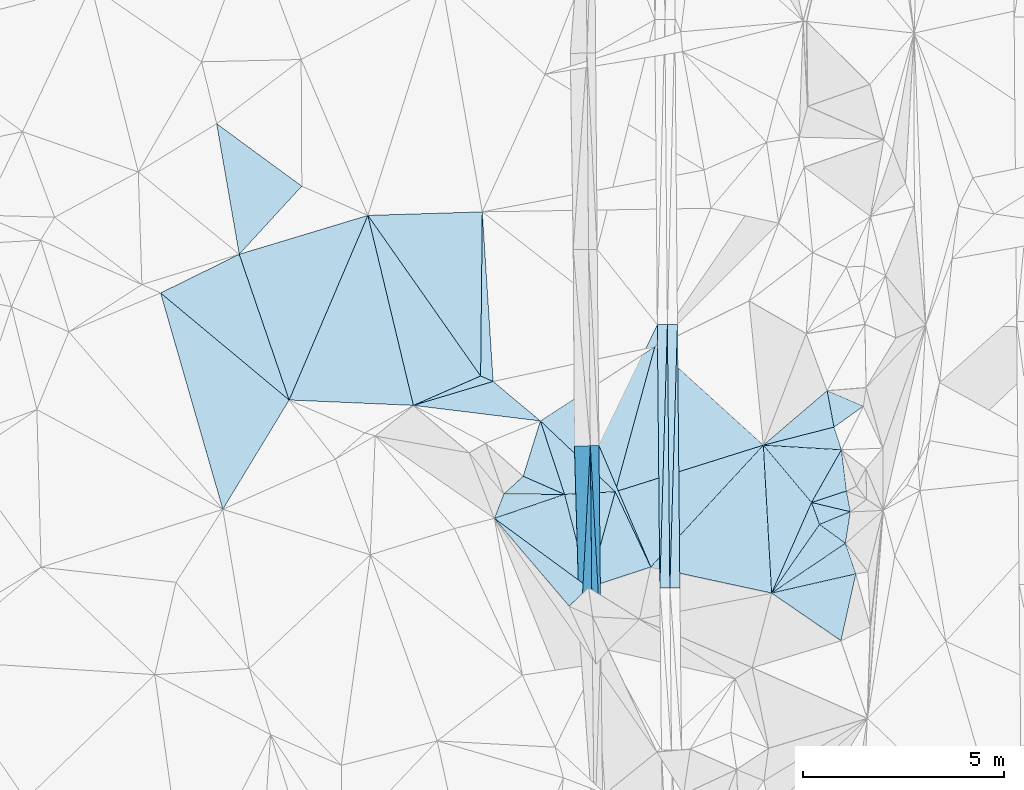
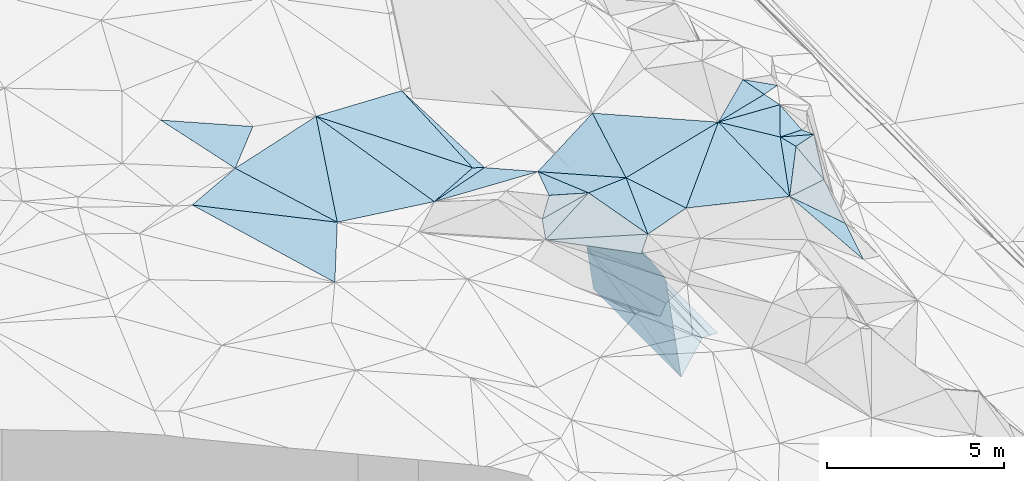
# One storey, part 18 of 275: 45 plates.
"""IFC2X3 building model written with IfcOpenShell, lengths in millimetres."""

from ifc_helpers import new_model, si_unit, frame, origin_with_axes, place, context, subcontext, project, spatial, polyline, outline, extrude, material, type_object, element, save


model = new_model("IFC2X3")

# Units and contexts
model_context = context("Model", 3, precision=1e-05, world=origin_with_axes())
body_context = subcontext(model_context, "Body", "Model", "MODEL_VIEW")
ifc_project = project(units=[si_unit("LENGTHUNIT", "METRE", prefix="MILLI"), si_unit("AREAUNIT", "SQUARE_METRE"), si_unit("VOLUMEUNIT", "CUBIC_METRE"), si_unit("MASSUNIT", "GRAM", prefix="KILO"), si_unit("TIMEUNIT", "SECOND"), si_unit("PLANEANGLEUNIT", "RADIAN"), si_unit("SOLIDANGLEUNIT", "STERADIAN"), si_unit("THERMODYNAMICTEMPERATUREUNIT", "DEGREE_CELSIUS"), si_unit("LUMINOUSINTENSITYUNIT", "LUMEN")], contexts=[model_context])

# Site, building, storey
site_placement = place(None, origin_with_axes())
site = spatial("IfcSite", under=ifc_project, at=site_placement, CompositionType="ELEMENT")
building_placement = place(site_placement, origin_with_axes())
building = spatial("IfcBuilding", under=site, at=building_placement, Name="Undefined", CompositionType="ELEMENT")
storey_placement = place(building_placement, origin_with_axes())
storey = spatial("IfcBuildingStorey", under=building, at=storey_placement, Name="Undefined", CompositionType="ELEMENT", Elevation=0.0)

# Plates
ifc_material = material()
plate_type_1 = type_object("IfcPlateType", PredefinedType="NOTDEFINED")
plate_1_placement = place(storey_placement, frame((-103609.10241154, 29331.890004464, 41830.4527314809), z_axis=(0.0497189597427629, 0.021119356383845, -0.998539933016216), x_axis=(0.00942336010166132, -0.999741827176861, -0.0206755719984943)))
element("IfcPlate", 1, at=plate_1_placement, inside=storey, type_object=plate_type_1, material=ifc_material, Name="00_PR", context=body_context, shape_type="SweptSolid", body=[
    extrude(outline(polyline([(0.0, 0.0), (6559.47998046875, 5.80621417611837e-09), (6559.8740234375, 250.312072753906), (0.0, 0.0)])), frame((-8.85201319254618e-08, 2.18876761149539e-07, -0.5000001331573), z_axis=(0.0, 0.0, 1.0), x_axis=(1.0, 0.0, 0.0)), (0.0, 0.0, 1.0), 1.0),
])
plate_2_placement = place(storey_placement, frame((-103859.092883656, 29329.669323517, 41817.9527319857), z_axis=(0.0497412450180932, 0.0211186916750077, -0.998538837204636), x_axis=(0.998712939479923, 0.00887162411305846, 0.0499375490084139)))
element("IfcPlate", 2, at=plate_2_placement, inside=storey, type_object=plate_type_1, material=ifc_material, Name="00_PR", context=body_context, shape_type="SweptSolid", body=[
    extrude(outline(polyline([(0.0, 0.0), (250.312698364258, -9.60426405072212e-10), (-3.21760201454163, 6559.75048828125), (0.0, 0.0)])), frame((-8.85201319254618e-08, 2.18876761149539e-07, -0.5000001331573), z_axis=(0.0, 0.0, 1.0), x_axis=(1.0, 0.0, 0.0)), (0.0, 0.0, 1.0), 1.0),
])
plate_3_placement = place(storey_placement, frame((-103547.325030308, 22774.1030868264, 41694.8312079371), z_axis=(-0.0201969752036263, 0.0204828383936473, -0.999586182139371), x_axis=(0.0286680488941595, 0.99939088915696, 0.0198995890073842)))
element("IfcPlate", 3, at=plate_3_placement, inside=storey, type_object=plate_type_1, material=ifc_material, Name="00_PR", context=body_context, shape_type="SweptSolid", body=[
    extrude(outline(polyline([(0.0, 0.0), (6564.0048828125, -3.34694050252438e-10), (9.55822658538818, 249.866928100586), (0.0, 0.0)])), frame((-8.85201319254618e-08, 2.18876761149539e-07, -0.5000001331573), z_axis=(0.0, 0.0, 1.0), x_axis=(1.0, 0.0, 0.0)), (0.0, 0.0, 1.0), 1.0),
])
plate_4_placement = place(storey_placement, frame((-103359.14779484, 29334.109961642, 41825.4522074339), z_axis=(-0.0201744797587791, 0.0204822013867093, -0.999586649467077), x_axis=(-0.0286680488809871, -0.999390889177604, -0.0198995879896055)))
element("IfcPlate", 4, at=plate_4_placement, inside=storey, type_object=plate_type_1, material=ifc_material, Name="00_PR", context=body_context, shape_type="SweptSolid", body=[
    extrude(outline(polyline([(0.0, 0.0), (6564.0048828125, -3.34694050252438e-10), (9.2861385345459, 249.876922607422), (0.0, 0.0)])), frame((-8.85201319254618e-08, 2.18876761149539e-07, -0.5000001331573), z_axis=(0.0, 0.0, 1.0), x_axis=(1.0, 0.0, 0.0)), (0.0, 0.0, 1.0), 1.0),
])
plate_type_2 = type_object("IfcPlateType", PredefinedType="NOTDEFINED")
plate_5_placement = place(storey_placement, frame((-99055.7095821679, 24674.3928783165, 45909.5237554857), z_axis=(-0.168807420396728, -0.253568631692106, -0.952474148646983), x_axis=(-0.966984833365667, 0.229769833923114, 0.110209597856621)))
element("IfcPlate", 5, at=plate_5_placement, inside=storey, type_object=plate_type_2, material=ifc_material, Name="00", context=body_context, shape_type="SweptSolid", body=[
    extrude(outline(polyline([(0.0, 0.0), (998.098205566406, -2.29920260608196e-09), (198.37727355957, 499.546264648438), (0.0, 0.0)])), frame((-8.85201319254618e-08, 2.18876761149539e-07, -0.5000001331573), z_axis=(0.0, 0.0, 1.0), x_axis=(1.0, 0.0, 0.0)), (0.0, 0.0, 1.0), 1.0),
])
plate_type_3 = type_object("IfcPlateType", PredefinedType="NOTDEFINED")
plate_6_placement = place(storey_placement, frame((-105264.390079401, 21434.0374164795, 41655.2352918188), z_axis=(-0.989926541019541, -0.00675050849142688, -0.141420910830731), x_axis=(-0.141414167012592, -0.00144075398867018, 0.989949472243952)))
element("IfcPlate", 6, at=plate_6_placement, inside=storey, type_object=plate_type_3, material=ifc_material, Name="00_PR", context=body_context, shape_type="SweptSolid", body=[
    extrude(outline(polyline([(0.0, 0.0), (1515.22888183594, -4.05998434871435e-09), (1615.31982421875, 4885.205078125), (0.0, 0.0)])), frame((-8.85201319254618e-08, 2.18876761149539e-07, -0.5000001331573), z_axis=(0.0, 0.0, 1.0), x_axis=(1.0, 0.0, 0.0)), (0.0, 0.0, 1.0), 1.0),
])
plate_7_placement = place(storey_placement, frame((-105526.460321508, 26316.7988611923, 43256.624291726), z_axis=(-0.989926541019541, -0.00675050849142688, -0.141420910830731), x_axis=(0.141415544961901, 0.0013266330082938, -0.989949434914728)))
element("IfcPlate", 7, at=plate_7_placement, inside=storey, type_object=plate_type_3, material=ifc_material, Name="00_PR", context=body_context, shape_type="SweptSolid", body=[
    extrude(outline(polyline([(0.0, 0.0), (1515.22888183594, -4.05998434871435e-09), (1615.87731933594, 4885.0205078125), (0.0, 0.0)])), frame((-8.85201319254618e-08, 2.18876761149539e-07, -0.5000001331573), z_axis=(0.0, 0.0, 1.0), x_axis=(1.0, 0.0, 0.0)), (0.0, 0.0, 1.0), 1.0),
])
plate_type_4 = type_object("IfcPlateType", PredefinedType="NOTDEFINED")
plate_8_placement = place(storey_placement, frame((-105526.460321508, 26316.7988611923, 43256.624291726), z_axis=(-0.989926541019541, -0.00675050849142688, -0.141420910830731), x_axis=(-0.0485562239280286, -0.922096443268798, 0.383901605139759)))
element("IfcPlate", 8, at=plate_8_placement, inside=storey, type_object=plate_type_4, material=ifc_material, Name="00_PR", context=body_context, shape_type="SweptSolid", body=[
    extrude(outline(polyline([(0.0, 0.0), (5301.0224609375, 2.91765900328755e-09), (1088.08190917969, 2583.6025390625), (0.0, 0.0)])), frame((-8.85201319254618e-08, 2.18876761149539e-07, -0.5000001331573), z_axis=(0.0, 0.0, 1.0), x_axis=(1.0, 0.0, 0.0)), (0.0, 0.0, 1.0), 1.0),
])
plate_type_5 = type_object("IfcPlateType", PredefinedType="NOTDEFINED")
plate_9_placement = place(storey_placement, frame((-105526.460321508, 26316.7988611923, 43256.624291726), z_axis=(-0.989926541019541, -0.00675050849142688, -0.141420910830731), x_axis=(0.00978165408462092, -0.999736844929714, -0.020749942972222)))
element("IfcPlate", 9, at=plate_9_placement, inside=storey, type_object=plate_type_5, material=ifc_material, Name="00_PR", context=body_context, shape_type="SweptSolid", body=[
    extrude(outline(polyline([(0.0, 0.0), (4886.23046875, 2.02999217435718e-09), (4842.02197265625, 2157.69775390625), (0.0, 0.0)])), frame((-8.85201319254618e-08, 2.18876761149539e-07, -0.5000001331573), z_axis=(0.0, 0.0, 1.0), x_axis=(1.0, 0.0, 0.0)), (0.0, 0.0, 1.0), 1.0),
])
plate_type_6 = type_object("IfcPlateType", PredefinedType="NOTDEFINED")
plate_10_placement = place(storey_placement, frame((-105263.895198522, 21434.0511645319, 41654.8061091048), z_axis=(-0.000160533861651392, 0.0207500994786471, -0.999784680619035), x_axis=(-0.00978157109525467, 0.999736830506762, 0.0207506769817859)))
element("IfcPlate", 10, at=plate_10_placement, inside=storey, type_object=plate_type_6, material=ifc_material, Name="00_PR", context=body_context, shape_type="SweptSolid", body=[
    extrude(outline(polyline([(0.0, 0.0), (4886.0576171875, 6.33008312433958e-09), (1323.43395996094, 1479.60864257813), (0.0, 0.0)])), frame((-8.85201319254618e-08, 2.18876761149539e-07, -0.5000001331573), z_axis=(0.0, 0.0, 1.0), x_axis=(1.0, 0.0, 0.0)), (0.0, 0.0, 1.0), 1.0),
])
plate_type_7 = type_object("IfcPlateType", PredefinedType="NOTDEFINED")
plate_11_placement = place(storey_placement, frame((-105311.688614487, 26318.822722426, 41756.1951082799), z_axis=(-0.000342593725236257, 0.0206724062372525, -0.999786244279197), x_axis=(0.434446549891689, 0.900508204036442, 0.0184707809869803)))
element("IfcPlate", 11, at=plate_11_placement, inside=storey, type_object=plate_type_7, material=ifc_material, Name="00_PR", context=body_context, shape_type="SweptSolid", body=[
    extrude(outline(polyline([(0.0, 0.0), (3343.49682617188, 1.32276909425855e-08), (-2537.7373046875, 2905.41162109375), (0.0, 0.0)])), frame((-8.85201319254618e-08, 2.18876761149539e-07, -0.5000001331573), z_axis=(0.0, 0.0, 1.0), x_axis=(1.0, 0.0, 0.0)), (0.0, 0.0, 1.0), 1.0),
])
plate_type_8 = type_object("IfcPlateType", PredefinedType="NOTDEFINED")
plate_12_placement = place(storey_placement, frame((-99823.1430053519, 24357.469140405, 45959.7053277046), z_axis=(-0.614024419711721, 0.525037597430078, -0.589329732223427), x_axis=(0.477436598125638, -0.347498338931752, -0.807031101761197)))
element("IfcPlate", 12, at=plate_12_placement, inside=storey, type_object=plate_type_8, material=ifc_material, Name="00", context=body_context, shape_type="SweptSolid", body=[
    extrude(outline(polyline([(0.0, 0.0), (1350.62951660156, -1.4042598195374e-09), (250.549835205078, 2085.76708984375), (0.0, 0.0)])), frame((-8.85201319254618e-08, 2.18876761149539e-07, -0.5000001331573), z_axis=(0.0, 0.0, 1.0), x_axis=(1.0, 0.0, 0.0)), (0.0, 0.0, 1.0), 1.0),
])
plate_type_9 = type_object("IfcPlateType", PredefinedType="NOTDEFINED")
plate_13_placement = place(storey_placement, frame((-105569.724939468, 22789.6759321737, 45889.5029484699), z_axis=(0.0260483191934787, 0.105434900437146, -0.994084989745346), x_axis=(-0.248665922200705, 0.96384877005615, 0.0957121078929928)))
element("IfcPlate", 13, at=plate_13_placement, inside=storey, type_object=plate_type_9, material=ifc_material, Name="00", context=body_context, shape_type="SweptSolid", body=[
    extrude(outline(polyline([(0.0, 0.0), (2403.03979492188, -1.42608769237995e-09), (2156.43530273438, 1239.22814941406), (0.0, 0.0)])), frame((-8.85201319254618e-08, 2.18876761149539e-07, -0.5000001331573), z_axis=(0.0, 0.0, 1.0), x_axis=(1.0, 0.0, 0.0)), (0.0, 0.0, 1.0), 1.0),
])
plate_type_10 = type_object("IfcPlateType", PredefinedType="NOTDEFINED")
plate_14_placement = place(storey_placement, frame((-99278.1640767034, 26216.3655026955, 46079.538906625), z_axis=(-0.317021325451936, 0.221580509541041, -0.922171110478001), x_axis=(0.117205319232085, -0.95571888725025, -0.269933920982247)))
element("IfcPlate", 14, at=plate_14_placement, inside=storey, type_object=plate_type_10, material=ifc_material, Name="00", context=body_context, shape_type="SweptSolid", body=[
    extrude(outline(polyline([(0.0, 0.0), (1074.33703613281, 9.60426405072212e-10), (1183.42749023438, 936.589172363281), (0.0, 0.0)])), frame((-8.85201319254618e-08, 2.18876761149539e-07, -0.5000001331573), z_axis=(0.0, 0.0, 1.0), x_axis=(1.0, 0.0, 0.0)), (0.0, 0.0, 1.0), 1.0),
])
plate_type_11 = type_object("IfcPlateType", PredefinedType="NOTDEFINED")
plate_15_placement = place(storey_placement, frame((-106167.184533557, 25106.0354002289, 46119.5777665701), z_axis=(0.215048342491864, 0.49057229080455, -0.844448363066847), x_axis=(-0.96985593287009, 0.00580962981849526, -0.243609765153329)))
element("IfcPlate", 15, at=plate_15_placement, inside=storey, type_object=plate_type_11, material=ifc_material, Name="00", context=body_context, shape_type="SweptSolid", body=[
    extrude(outline(polyline([(0.0, 0.0), (1559.87182617188, 4.07453626394272e-10), (1002.26184082031, 511.831176757813), (0.0, 0.0)])), frame((-8.85201319254618e-08, 2.18876761149539e-07, -0.5000001331573), z_axis=(0.0, 0.0, 1.0), x_axis=(1.0, 0.0, 0.0)), (0.0, 0.0, 1.0), 1.0),
])
plate_16_placement = place(storey_placement, frame((-107913.83332322, 24508.6997456536, 45468.5408983652), z_axis=(0.2325516148256, 0.320717919634269, -0.918182858948844), x_axis=(0.332076183784581, 0.861147978046191, 0.384902023987957)))
element("IfcPlate", 16, at=plate_16_placement, inside=storey, type_object=plate_type_11, material=ifc_material, Name="00", context=body_context, shape_type="SweptSolid", body=[
    extrude(outline(polyline([(0.0, 0.0), (704.075256347656, 6.25732354819775e-10), (1344.91589355469, 1422.15454101563), (0.0, 0.0)])), frame((-8.85201319254618e-08, 2.18876761149539e-07, -0.5000001331573), z_axis=(0.0, 0.0, 1.0), x_axis=(1.0, 0.0, 0.0)), (0.0, 0.0, 1.0), 1.0),
])
plate_type_12 = type_object("IfcPlateType", PredefinedType="NOTDEFINED")
plate_17_placement = place(storey_placement, frame((-104906.083157872, 25171.3032361768, 46159.5018413628), z_axis=(0.0356631735644278, -0.0781985219319397, -0.996299718568149), x_axis=(-0.998151409522378, -0.0518803561468019, -0.031657421161095)))
element("IfcPlate", 17, at=plate_17_placement, inside=storey, type_object=plate_type_12, material=ifc_material, Name="00", context=body_context, shape_type="SweptSolid", body=[
    extrude(outline(polyline([(0.0, 0.0), (1263.52685546875, -1.08411768451333e-09), (1775.19775390625, 1862.25317382813), (0.0, 0.0)])), frame((-8.85201319254618e-08, 2.18876761149539e-07, -0.5000001331573), z_axis=(0.0, 0.0, 1.0), x_axis=(1.0, 0.0, 0.0)), (0.0, 0.0, 1.0), 1.0),
])
plate_type_13 = type_object("IfcPlateType", PredefinedType="NOTDEFINED")
plate_18_placement = place(storey_placement, frame((-99278.003944456, 26216.3254637948, 46079.5050258497), z_axis=(0.00324425029513097, 0.141502961289554, -0.989932516278918), x_axis=(-0.998253867274184, 0.0588455358523238, 0.00513997883146703)))
element("IfcPlate", 18, at=plate_18_placement, inside=storey, type_object=plate_type_13, material=ifc_material, Name="00", context=body_context, shape_type="SweptSolid", body=[
    extrude(outline(polyline([(0.0, 0.0), (1945.53332519531, -1.07756932266057e-08), (216.95849609375, 557.699768066406), (0.0, 0.0)])), frame((-8.85201319254618e-08, 2.18876761149539e-07, -0.5000001331573), z_axis=(0.0, 0.0, 1.0), x_axis=(1.0, 0.0, 0.0)), (0.0, 0.0, 1.0), 1.0),
])
plate_type_14 = type_object("IfcPlateType", PredefinedType="NOTDEFINED")
plate_19_placement = place(storey_placement, frame((-105569.596620118, 22789.70019235, 45889.5266194305), z_axis=(0.282886238039276, 0.153919603057811, -0.946722838069576), x_axis=(-0.684586285721497, -0.658932377530241, -0.311688529215288)))
element("IfcPlate", 19, at=plate_19_placement, inside=storey, type_object=plate_type_14, material=ifc_material, Name="00", context=body_context, shape_type="SweptSolid", body=[
    extrude(outline(polyline([(0.0, 0.0), (705.832824707031, 1.04773789644241e-09), (603.386474609375, 2874.57250976563), (0.0, 0.0)])), frame((-8.85201319254618e-08, 2.18876761149539e-07, -0.5000001331573), z_axis=(0.0, 0.0, 1.0), x_axis=(1.0, 0.0, 0.0)), (0.0, 0.0, 1.0), 1.0),
])
plate_type_15 = type_object("IfcPlateType", PredefinedType="NOTDEFINED")
plate_20_placement = place(storey_placement, frame((-108257.180907625, 28052.4555961393, 45929.5070274394), z_axis=(0.00943407743171563, 0.167017442115437, -0.985908805220964), x_axis=(0.915224935912619, -0.398634024212941, -0.058772709853631)))
element("IfcPlate", 20, at=plate_20_placement, inside=storey, type_object=plate_type_15, material=ifc_material, Name="00", context=body_context, shape_type="SweptSolid", body=[
    extrude(outline(polyline([(0.0, 0.0), (340.293975830078, 1.09503162093461e-09), (-1231.08251953125, 1355.86157226563), (0.0, 0.0)])), frame((-8.85201319254618e-08, 2.18876761149539e-07, -0.5000001331573), z_axis=(0.0, 0.0, 1.0), x_axis=(1.0, 0.0, 0.0)), (0.0, 0.0, 1.0), 1.0),
])
plate_type_16 = type_object("IfcPlateType", PredefinedType="NOTDEFINED")
plate_21_placement = place(storey_placement, frame((-99178.1720817674, 23888.248136467, 44869.7309848444), z_axis=(-0.351871818792873, 0.765994780021304, -0.53799462833704), x_axis=(-0.477436598272804, 0.347498338652373, 0.807031101794431)))
element("IfcPlate", 21, at=plate_21_placement, inside=storey, type_object=plate_type_16, material=ifc_material, Name="00", context=body_context, shape_type="SweptSolid", body=[
    extrude(outline(polyline([(0.0, 0.0), (1350.62951660156, -1.4042598195374e-09), (1054.24914550781, 777.147827148438), (0.0, 0.0)])), frame((-8.85201319254618e-08, 2.18876761149539e-07, -0.5000001331573), z_axis=(0.0, 0.0, 1.0), x_axis=(1.0, 0.0, 0.0)), (0.0, 0.0, 1.0), 1.0),
])
plate_type_17 = type_object("IfcPlateType", PredefinedType="NOTDEFINED")
plate_22_placement = place(storey_placement, frame((-99633.5173044898, 27688.2062355976, 46179.5004558845), z_axis=(0.0325720534300295, 0.0281685404016658, -0.99907236708208), x_axis=(0.185897097271178, -0.982330982523094, -0.0216358499107901)))
element("IfcPlate", 22, at=plate_22_placement, inside=storey, type_object=plate_type_17, material=ifc_material, Name="00", context=body_context, shape_type="SweptSolid", body=[
    extrude(outline(polyline([(0.0, 0.0), (924.391662597656, -1.74622982740402e-10), (1040.46801757813, 1812.60205078125), (0.0, 0.0)])), frame((-8.85201319254618e-08, 2.18876761149539e-07, -0.5000001331573), z_axis=(0.0, 0.0, 1.0), x_axis=(1.0, 0.0, 0.0)), (0.0, 0.0, 1.0), 1.0),
])
plate_type_18 = type_object("IfcPlateType", PredefinedType="NOTDEFINED")
plate_23_placement = place(storey_placement, frame((-98729.7746286093, 27300.5662905899, 45899.5250732756), z_axis=(-0.310446899118105, -0.0378290327464111, -0.949837716196522), x_axis=(-0.782886836614798, -0.556577079866461, 0.278047037787847)))
element("IfcPlate", 23, at=plate_23_placement, inside=storey, type_object=plate_type_18, material=ifc_material, Name="00", context=body_context, shape_type="SweptSolid", body=[
    extrude(outline(polyline([(0.0, 0.0), (935.093566894531, 3.05590219795704e-09), (569.782531738281, 849.145385742188), (0.0, 0.0)])), frame((-8.85201319254618e-08, 2.18876761149539e-07, -0.5000001331573), z_axis=(0.0, 0.0, 1.0), x_axis=(1.0, 0.0, 0.0)), (0.0, 0.0, 1.0), 1.0),
])
plate_type_19 = type_object("IfcPlateType", PredefinedType="NOTDEFINED")
plate_24_placement = place(storey_placement, frame((-101220.10242062, 26330.7980143766, 46089.5048515537), z_axis=(0.0786628518864588, 0.114701052291202, -0.990280679573413), x_axis=(0.642985645085362, -0.76495828084813, -0.037527173834886)))
element("IfcPlate", 24, at=plate_24_placement, inside=storey, type_object=plate_type_19, material=ifc_material, Name="00", context=body_context, shape_type="SweptSolid", body=[
    extrude(outline(polyline([(0.0, 0.0), (1865.31494140625, -9.62609192356467e-09), (2963.681640625, 2230.96166992188), (0.0, 0.0)])), frame((-8.85201319254618e-08, 2.18876761149539e-07, -0.5000001331573), z_axis=(0.0, 0.0, 1.0), x_axis=(1.0, 0.0, 0.0)), (0.0, 0.0, 1.0), 1.0),
])
plate_25_placement = place(storey_placement, frame((-98918.8549506062, 23128.1644994404, 43729.7363787382), z_axis=(-0.622557701767406, 0.578318486885234, -0.527228257680542), x_axis=(-0.722076372203824, -0.164763935091382, 0.671906658992279)))
element("IfcPlate", 25, at=plate_25_placement, inside=storey, type_object=plate_type_19, material=ifc_material, Name="00", context=body_context, shape_type="SweptSolid", body=[
    extrude(outline(polyline([(0.0, 0.0), (2902.18872070313, -7.63611751608551e-09), (828.09912109375, 1121.94116210938), (0.0, 0.0)])), frame((-8.85201319254618e-08, 2.18876761149539e-07, -0.5000001331573), z_axis=(0.0, 0.0, 1.0), x_axis=(1.0, 0.0, 0.0)), (0.0, 0.0, 1.0), 1.0),
])
plate_type_20 = type_object("IfcPlateType", PredefinedType="NOTDEFINED")
plate_26_placement = place(storey_placement, frame((-100020.77217824, 24903.8760227536, 46019.5005464549), z_axis=(-0.00237212192127091, 0.0470095430822076, -0.998891623699384), x_axis=(-0.642985645087453, 0.764958280846444, 0.0375271738334229)))
element("IfcPlate", 26, at=plate_26_placement, inside=storey, type_object=plate_type_20, material=ifc_material, Name="00", context=body_context, shape_type="SweptSolid", body=[
    extrude(outline(polyline([(0.0, 0.0), (1865.31494140625, -9.62609192356467e-09), (528.597045898438, 1413.60717773438), (0.0, 0.0)])), frame((-8.85201319254618e-08, 2.18876761149539e-07, -0.5000001331573), z_axis=(0.0, 0.0, 1.0), x_axis=(1.0, 0.0, 0.0)), (0.0, 0.0, 1.0), 1.0),
])
plate_type_21 = type_object("IfcPlateType", PredefinedType="NOTDEFINED")
plate_27_placement = place(storey_placement, frame((-99822.8837227967, 24357.2438158645, 45959.503667526), z_axis=(-0.0954588290501266, 0.0743888390736222, -0.992649944631872), x_axis=(-0.338659811354069, 0.935291874457019, 0.102657886926934)))
element("IfcPlate", 27, at=plate_27_placement, inside=storey, type_object=plate_type_21, material=ifc_material, Name="00", context=body_context, shape_type="SweptSolid", body=[
    extrude(outline(polyline([(0.0, 0.0), (584.465576171875, -7.27595761418343e-11), (31.8239440917969, 831.136108398438), (0.0, 0.0)])), frame((-8.85201319254618e-08, 2.18876761149539e-07, -0.5000001331573), z_axis=(0.0, 0.0, 1.0), x_axis=(1.0, 0.0, 0.0)), (0.0, 0.0, 1.0), 1.0),
])
plate_type_22 = type_object("IfcPlateType", PredefinedType="NOTDEFINED")
plate_28_placement = place(storey_placement, frame((-100020.745651158, 24903.9160578686, 46019.504694105), z_axis=(0.0506818780223728, 0.127079576320222, -0.990596854690342), x_axis=(0.338659811358073, -0.935291874456415, -0.102657886919222)))
element("IfcPlate", 28, at=plate_28_placement, inside=storey, type_object=plate_type_22, material=ifc_material, Name="00", context=body_context, shape_type="SweptSolid", body=[
    extrude(outline(polyline([(0.0, 0.0), (584.465576171875, -7.27595761418343e-11), (1806.77880859375, 1708.55212402344), (0.0, 0.0)])), frame((-8.85201319254618e-08, 2.18876761149539e-07, -0.5000001331573), z_axis=(0.0, 0.0, 1.0), x_axis=(1.0, 0.0, 0.0)), (0.0, 0.0, 1.0), 1.0),
])
plate_type_23 = type_object("IfcPlateType", PredefinedType="NOTDEFINED")
plate_29_placement = place(storey_placement, frame((-104906.10370184, 25171.3994015147, 46159.5032657684), z_axis=(-0.00542335591508727, 0.114132201735729, -0.993450767646577), x_axis=(0.423925102409152, -0.89951355244179, -0.105654514910349)))
element("IfcPlate", 29, at=plate_29_placement, inside=storey, type_object=plate_type_23, material=ifc_material, Name="00", context=body_context, shape_type="SweptSolid", body=[
    extrude(outline(polyline([(0.0, 0.0), (2082.25830078125, 7.71251507103443e-09), (1889.5830078125, 1617.21252441406), (0.0, 0.0)])), frame((-8.85201319254618e-08, 2.18876761149539e-07, -0.5000001331573), z_axis=(0.0, 0.0, 1.0), x_axis=(1.0, 0.0, 0.0)), (0.0, 0.0, 1.0), 1.0),
])
plate_type_24 = type_object("IfcPlateType", PredefinedType="NOTDEFINED")
plate_30_placement = place(storey_placement, frame((-106769.686876822, 26933.2269994627, 45954.5032773098), z_axis=(-0.0459593170361867, -0.104843252827774, -0.993426209395574), x_axis=(0.311904929000026, -0.946264225509232, 0.0854361210899811)))
element("IfcPlate", 30, at=plate_30_placement, inside=storey, type_object=plate_type_24, material=ifc_material, Name="00", context=body_context, shape_type="SweptSolid", body=[
    extrude(outline(polyline([(0.0, 0.0), (1931.26745605469, 3.37604433298111e-09), (1182.2412109375, 839.91650390625), (0.0, 0.0)])), frame((-8.85201319254618e-08, 2.18876761149539e-07, -0.5000001331573), z_axis=(0.0, 0.0, 1.0), x_axis=(1.0, 0.0, 0.0)), (0.0, 0.0, 1.0), 1.0),
])
plate_type_25 = type_object("IfcPlateType", PredefinedType="NOTDEFINED")
plate_31_placement = place(storey_placement, frame((-106769.651565899, 26933.2345407383, 45954.5021612964), z_axis=(0.0246614473751931, -0.0897601518438025, -0.995658037759118), x_axis=(0.838636784549475, 0.543957124900143, -0.0282664088785229)))
element("IfcPlate", 31, at=plate_31_placement, inside=storey, type_object=plate_type_25, material=ifc_material, Name="00", context=body_context, shape_type="SweptSolid", body=[
    extrude(outline(polyline([(0.0, 0.0), (3396.25732421875, -4.26371116191149e-09), (598.639587402344, 2502.18798828125), (0.0, 0.0)])), frame((-8.85201319254618e-08, 2.18876761149539e-07, -0.5000001331573), z_axis=(0.0, 0.0, 1.0), x_axis=(1.0, 0.0, 0.0)), (0.0, 0.0, 1.0), 1.0),
])
plate_type_26 = type_object("IfcPlateType", PredefinedType="NOTDEFINED")
plate_32_placement = place(storey_placement, frame((-99288.6919402492, 21466.5764399596, 43619.6529190088), z_axis=(-0.69152615811343, 0.199882266022499, -0.694145987796941), x_axis=(-0.587741455013733, 0.40296053682792, 0.701557401655556)))
element("IfcPlate", 32, at=plate_32_placement, inside=storey, type_object=plate_type_26, material=ifc_material, Name="00", context=body_context, shape_type="SweptSolid", body=[
    extrude(outline(polyline([(0.0, 0.0), (2936.32421875, 8.70204530656338e-09), (529.301208496094, 1621.40075683594), (0.0, 0.0)])), frame((-8.85201319254618e-08, 2.18876761149539e-07, -0.5000001331573), z_axis=(0.0, 0.0, 1.0), x_axis=(1.0, 0.0, 0.0)), (0.0, 0.0, 1.0), 1.0),
])
plate_type_27 = type_object("IfcPlateType", PredefinedType="NOTDEFINED")
plate_33_placement = place(storey_placement, frame((-101014.17698686, 22649.7527953339, 45679.503851284), z_axis=(-0.0626673331815142, 0.107014767887273, -0.992280527273387), x_axis=(-0.974081414694494, 0.209957769766729, 0.0841613477871747)))
element("IfcPlate", 33, at=plate_33_placement, inside=storey, type_object=plate_type_27, material=ifc_material, Name="00", context=body_context, shape_type="SweptSolid", body=[
    extrude(outline(polyline([(0.0, 0.0), (3089.30419921875, 2.21643858822063e-09), (1008.0263671875, 3569.94165039063), (0.0, 0.0)])), frame((-8.85201319254618e-08, 2.18876761149539e-07, -0.5000001331573), z_axis=(0.0, 0.0, 1.0), x_axis=(1.0, 0.0, 0.0)), (0.0, 0.0, 1.0), 1.0),
])
plate_type_28 = type_object("IfcPlateType", PredefinedType="NOTDEFINED")
plate_34_placement = place(storey_placement, frame((-104023.403611156, 23298.3696780864, 45939.5027928044), z_axis=(-0.0484420687761435, 0.093969239474668, -0.994395870870973), x_axis=(-0.423925102401145, 0.899513552443088, 0.105654514931424)))
element("IfcPlate", 34, at=plate_34_placement, inside=storey, type_object=plate_type_28, material=ifc_material, Name="00", context=body_context, shape_type="SweptSolid", body=[
    extrude(outline(polyline([(0.0, 0.0), (2082.25830078125, 7.71251507103443e-09), (1555.18640136719, 3828.52392578125), (0.0, 0.0)])), frame((-8.85201319254618e-08, 2.18876761149539e-07, -0.5000001331573), z_axis=(0.0, 0.0, 1.0), x_axis=(1.0, 0.0, 0.0)), (0.0, 0.0, 1.0), 1.0),
])
plate_type_29 = type_object("IfcPlateType", PredefinedType="NOTDEFINED")
plate_35_placement = place(storey_placement, frame((-104906.097045384, 25171.2997137991, 46159.5018256624), z_axis=(0.00789079938079536, -0.0852409379180982, -0.996329121218473), x_axis=(0.262342801823028, 0.961636625897497, -0.0801951000006916)))
element("IfcPlate", 35, at=plate_35_placement, inside=storey, type_object=plate_type_29, material=ifc_material, Name="00", context=body_context, shape_type="SweptSolid", body=[
    extrude(outline(polyline([(0.0, 0.0), (3753.34643554688, 3.20142135024071e-10), (2087.51831054688, 3252.33251953125), (0.0, 0.0)])), frame((-8.85201319254618e-08, 2.18876761149539e-07, -0.5000001331573), z_axis=(0.0, 0.0, 1.0), x_axis=(1.0, 0.0, 0.0)), (0.0, 0.0, 1.0), 1.0),
])
plate_type_30 = type_object("IfcPlateType", PredefinedType="NOTDEFINED")
plate_36_placement = place(storey_placement, frame((-106167.145582329, 25105.8746278799, 46119.5294559905), z_axis=(0.292949756854871, 0.16902886038618, -0.941068373878976), x_axis=(0.248665922189335, -0.963848770058165, -0.095712107902245)))
element("IfcPlate", 36, at=plate_36_placement, inside=storey, type_object=plate_type_30, material=ifc_material, Name="00", context=body_context, shape_type="SweptSolid", body=[
    extrude(outline(polyline([(0.0, 0.0), (2403.03979492188, -1.42608769237995e-09), (203.633758544922, 1946.75512695313), (0.0, 0.0)])), frame((-8.85201319254618e-08, 2.18876761149539e-07, -0.5000001331573), z_axis=(0.0, 0.0, 1.0), x_axis=(1.0, 0.0, 0.0)), (0.0, 0.0, 1.0), 1.0),
])
plate_type_31 = type_object("IfcPlateType", PredefinedType="NOTDEFINED")
plate_37_placement = place(storey_placement, frame((-107945.762996226, 27916.7403198483, 45909.5009464297), z_axis=(-0.0458017911051023, 0.0419938803055297, -0.998067487672276), x_axis=(-0.915224935867654, 0.398634024321707, 0.0587727098161216)))
element("IfcPlate", 37, at=plate_37_placement, inside=storey, type_object=plate_type_31, material=ifc_material, Name="00", context=body_context, shape_type="SweptSolid", body=[
    extrude(outline(polyline([(0.0, 0.0), (340.293975830078, 1.09503162093461e-09), (1940.96875, 3763.14233398438), (0.0, 0.0)])), frame((-8.85201319254618e-08, 2.18876761149539e-07, -0.5000001331573), z_axis=(0.0, 0.0, 1.0), x_axis=(1.0, 0.0, 0.0)), (0.0, 0.0, 1.0), 1.0),
])
plate_type_32 = type_object("IfcPlateType", PredefinedType="NOTDEFINED")
plate_38_placement = place(storey_placement, frame((-111062.913085063, 32049.2536138247, 46269.5035764975), z_axis=(-0.0896685883982667, 0.0792962996740772, -0.992809972307219), x_axis=(0.231832830645748, -0.967782631703299, -0.0982360239841653)))
element("IfcPlate", 38, at=plate_38_placement, inside=storey, type_object=plate_type_32, material=ifc_material, Name="00", context=body_context, shape_type="SweptSolid", body=[
    extrude(outline(polyline([(0.0, 0.0), (4886.19140625, -7.08678271621466e-09), (4011.02392578125, 2983.01635742188), (0.0, 0.0)])), frame((-8.85201319254618e-08, 2.18876761149539e-07, -0.5000001331573), z_axis=(0.0, 0.0, 1.0), x_axis=(1.0, 0.0, 0.0)), (0.0, 0.0, 1.0), 1.0),
])
plate_type_33 = type_object("IfcPlateType", PredefinedType="NOTDEFINED")
plate_39_placement = place(storey_placement, frame((-111062.850591286, 32049.2686124641, 46269.5032910089), z_axis=(0.0353145982158057, 0.109294143793881, -0.993381935252106), x_axis=(0.57315910846501, -0.81649517545791, -0.0694569279305698)))
element("IfcPlate", 39, at=plate_39_placement, inside=storey, type_object=plate_type_33, material=ifc_material, Name="00", context=body_context, shape_type="SweptSolid", body=[
    extrude(outline(polyline([(0.0, 0.0), (4895.1201171875, -2.32976162806153e-08), (4543.62109375, 1797.32397460938), (0.0, 0.0)])), frame((-8.85201319254618e-08, 2.18876761149539e-07, -0.5000001331573), z_axis=(0.0, 0.0, 1.0), x_axis=(1.0, 0.0, 0.0)), (0.0, 0.0, 1.0), 1.0),
])
plate_type_34 = type_object("IfcPlateType", PredefinedType="NOTDEFINED")
plate_40_placement = place(storey_placement, frame((-114827.378267597, 34331.9796651935, 46069.5007772274), z_axis=(-0.0391865063269888, -0.0405683831635099, -0.998408044844083), x_axis=(0.806214960634096, -0.591573825618415, -0.0076056619012877)))
element("IfcPlate", 40, at=plate_40_placement, inside=storey, type_object=plate_type_34, material=ifc_material, Name="00", context=body_context, shape_type="SweptSolid", body=[
    extrude(outline(polyline([(0.0, 0.0), (2629.61962890625, 8.40373104438186e-09), (2375.17236328125, 2291.43115234375), (0.0, 0.0)])), frame((-8.85201319254618e-08, 2.18876761149539e-07, -0.5000001331573), z_axis=(0.0, 0.0, 1.0), x_axis=(1.0, 0.0, 0.0)), (0.0, 0.0, 1.0), 1.0),
])
plate_type_35 = type_object("IfcPlateType", PredefinedType="NOTDEFINED")
plate_41_placement = place(storey_placement, frame((-113022.363766983, 27454.5662681127, 46079.5003447851), z_axis=(0.0179080915928618, 0.0336848758301262, -0.999272049742116), x_axis=(-0.324015655611763, 0.945692394660476, 0.0260720079743447)))
element("IfcPlate", 41, at=plate_41_placement, inside=storey, type_object=plate_type_35, material=ifc_material, Name="00", context=body_context, shape_type="SweptSolid", body=[
    extrude(outline(polyline([(0.0, 0.0), (3835.53125, -2.29920260608196e-09), (3715.18286132813, 3344.26611328125), (0.0, 0.0)])), frame((-8.85201319254618e-08, 2.18876761149539e-07, -0.5000001331573), z_axis=(0.0, 0.0, 1.0), x_axis=(1.0, 0.0, 0.0)), (0.0, 0.0, 1.0), 1.0),
])
plate_type_36 = type_object("IfcPlateType", PredefinedType="NOTDEFINED")
plate_42_placement = place(storey_placement, frame((-116222.623166787, 30117.9864802226, 46179.500779535), z_axis=(-0.0511693546010228, -0.0239964323448179, -0.998401656841792), x_axis=(0.768401731441622, -0.639517206483384, -0.0240108668982803)))
element("IfcPlate", 42, at=plate_42_placement, inside=storey, type_object=plate_type_36, material=ifc_material, Name="00", context=body_context, shape_type="SweptSolid", body=[
    extrude(outline(polyline([(0.0, 0.0), (4164.78076171875, 1.21508492156863e-08), (4631.81640625, 3151.01220703125), (0.0, 0.0)])), frame((-8.85201319254618e-08, 2.18876761149539e-07, -0.5000001331573), z_axis=(0.0, 0.0, 1.0), x_axis=(1.0, 0.0, 0.0)), (0.0, 0.0, 1.0), 1.0),
])
plate_type_37 = type_object("IfcPlateType", PredefinedType="NOTDEFINED")
plate_43_placement = place(storey_placement, frame((-113022.378526458, 27454.561216921, 46079.5001539195), z_axis=(-0.0116107772598502, 0.023581585296603, -0.999654489654461), x_axis=(-0.768401731436378, 0.639517206489388, 0.0240108669061872)))
element("IfcPlate", 43, at=plate_43_placement, inside=storey, type_object=plate_type_37, material=ifc_material, Name="00", context=body_context, shape_type="SweptSolid", body=[
    extrude(outline(polyline([(0.0, 0.0), (4164.78076171875, 1.21508492156863e-08), (3277.02709960938, 1993.08630371094), (0.0, 0.0)])), frame((-8.85201319254618e-08, 2.18876761149539e-07, -0.5000001331573), z_axis=(0.0, 0.0, 1.0), x_axis=(1.0, 0.0, 0.0)), (0.0, 0.0, 1.0), 1.0),
])
plate_type_38 = type_object("IfcPlateType", PredefinedType="NOTDEFINED")
plate_44_placement = place(storey_placement, frame((-106769.636739768, 26933.2891904193, 45954.5008192428), z_axis=(0.054510244276494, 0.0195067095589439, -0.9983226540308), x_axis=(-0.991249788081621, 0.121431694446813, -0.0517513401944034)))
element("IfcPlate", 44, at=plate_44_placement, inside=storey, type_object=plate_type_38, material=ifc_material, Name="00", context=body_context, shape_type="SweptSolid", body=[
    extrude(outline(polyline([(0.0, 0.0), (3188.3232421875, 1.9874278223142e-08), (1287.53479003906, 833.419616699219), (0.0, 0.0)])), frame((-8.85201319254618e-08, 2.18876761149539e-07, -0.5000001331573), z_axis=(0.0, 0.0, 1.0), x_axis=(1.0, 0.0, 0.0)), (0.0, 0.0, 1.0), 1.0),
])
plate_type_39 = type_object("IfcPlateType", PredefinedType="NOTDEFINED")
plate_45_placement = place(storey_placement, frame((-108257.216070843, 28052.3931455169, 45929.5013512814), z_axis=(-0.0608578200815382, 0.0421132165481327, -0.997257641097271), x_axis=(-0.573159108389316, 0.81649517551722, 0.0694569278579816)))
element("IfcPlate", 45, at=plate_45_placement, inside=storey, type_object=plate_type_39, material=ifc_material, Name="00", context=body_context, shape_type="SweptSolid", body=[
    extrude(outline(polyline([(0.0, 0.0), (4895.1201171875, -2.32976162806153e-08), (3323.94311523438, 2382.1845703125), (0.0, 0.0)])), frame((-8.85201319254618e-08, 2.18876761149539e-07, -0.5000001331573), z_axis=(0.0, 0.0, 1.0), x_axis=(1.0, 0.0, 0.0)), (0.0, 0.0, 1.0), 1.0),
])

save(model, "model.ifc")
